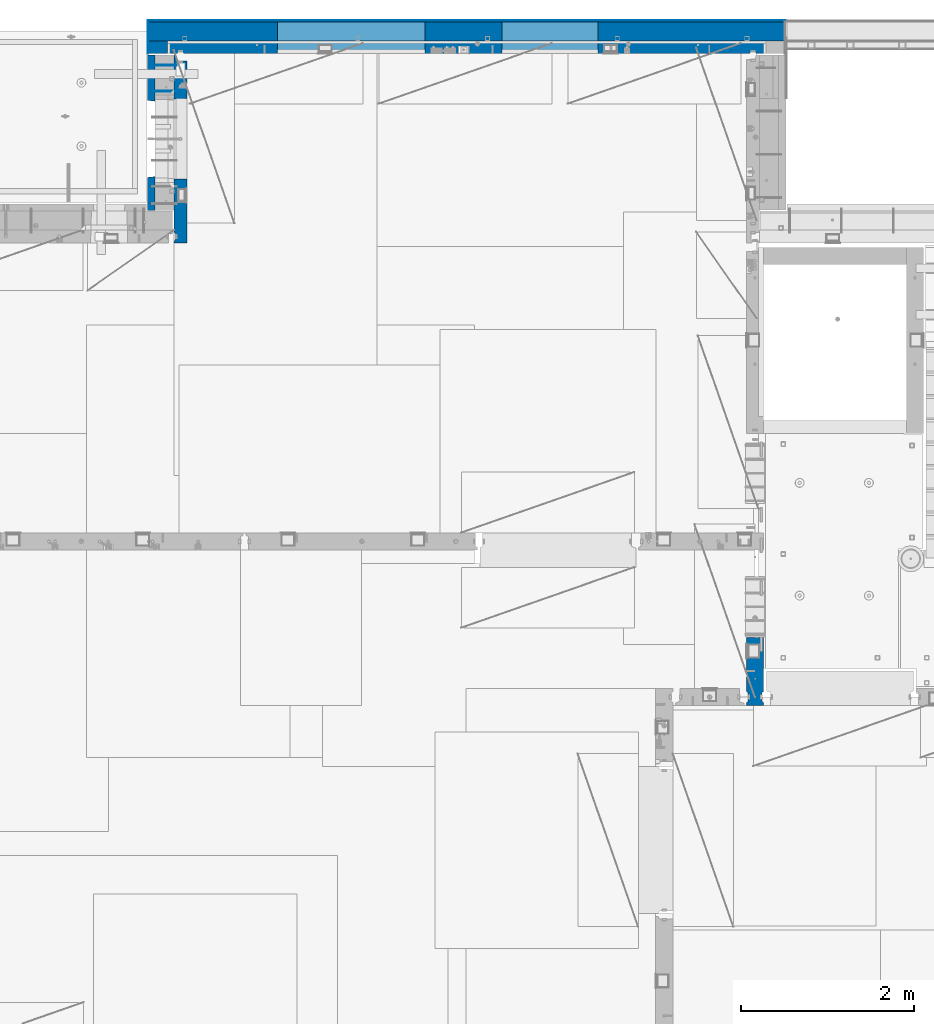
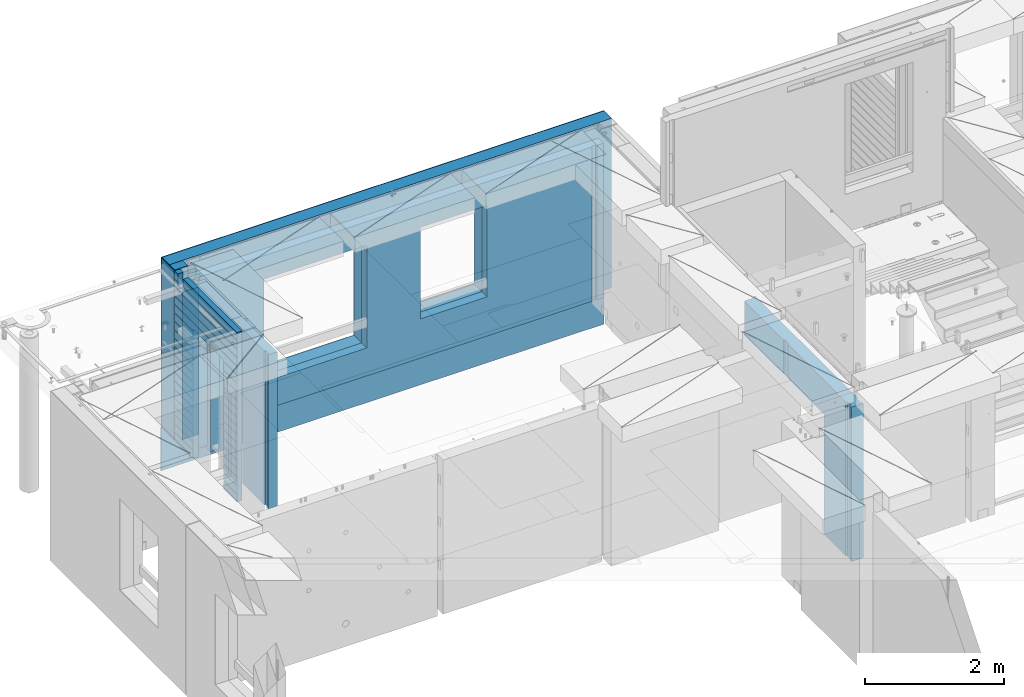
# One storey, part 237 of 350: 11 walls, 4 elements without a shape of their own.
"""IFC2X3 building model written with IfcOpenShell, lengths in millimetres."""

from ifc_helpers import new_model, si_unit, frame, origin_with_axes, place, context, subcontext, project, spatial, faceted_brep, material, type_object, element, aggregate, save


model = new_model("IFC2X3")

# Units and contexts
model_context = context("Model", 3, precision=1e-05, world=origin_with_axes())
body_context = subcontext(model_context, "Body", "Model", "MODEL_VIEW")
ifc_project = project(units=[si_unit("LENGTHUNIT", "METRE", prefix="MILLI"), si_unit("AREAUNIT", "SQUARE_METRE"), si_unit("VOLUMEUNIT", "CUBIC_METRE"), si_unit("MASSUNIT", "GRAM", prefix="KILO"), si_unit("TIMEUNIT", "SECOND"), si_unit("PLANEANGLEUNIT", "RADIAN"), si_unit("SOLIDANGLEUNIT", "STERADIAN"), si_unit("THERMODYNAMICTEMPERATUREUNIT", "DEGREE_CELSIUS"), si_unit("LUMINOUSINTENSITYUNIT", "LUMEN")], contexts=[model_context])

# Site, building, storey
site_placement = place(None, origin_with_axes())
site = spatial("IfcSite", under=ifc_project, at=site_placement, CompositionType="ELEMENT")
building_placement = place(site_placement, origin_with_axes())
building = spatial("IfcBuilding", under=site, at=building_placement, CompositionType="ELEMENT")
storey_placement = place(building_placement, origin_with_axes())
storey = spatial("IfcBuildingStorey", under=building, at=storey_placement, Name="2", CompositionType="ELEMENT", Elevation=0.0)

# Assembly, wall
assembly_1_placement = place(storey_placement, origin_with_axes())
assembly_1 = element("IfcElementAssembly", 1, at=assembly_1_placement, inside=storey, AssemblyPlace="NOTDEFINED", PredefinedType="REINFORCEMENT_UNIT")
ifc_material_1 = material(Name="CONCRETE/C30/37")
wall_type_1 = type_object("IfcWallType", PredefinedType="NOTDEFINED")
wall_1_placement = place(assembly_1_placement, frame((18064.9999998805, 23004.9999980536, 84357.5), z_axis=(0.0, 0.0, 1.0), x_axis=(-1.0, 3.00000001838171e-08, 0.0)))
wall_1 = element("IfcWall", 2, at=wall_1_placement, type_object=wall_type_1, material=ifc_material_1, context=body_context, shape_type="Brep", body=[
    faceted_brep([(0.0, 5.0, -382.5), (0.0, 5.0, 382.5), (7380.0035203153, 5.0, 382.5), (7380.0035203153, 5.0, -382.5), (-3.63797880709171e-12, -5.0, 382.5), (7380.0035203153, -5.0, 382.5), (-3.63797880709171e-12, -5.0, -382.5), (7380.0035203153, -5.0, -382.5)], [[[0, 1, 2, 3]], [[1, 4, 5, 2]], [[4, 6, 7, 5]], [[6, 0, 3, 7]], [[5, 7, 3, 2]], [[6, 4, 1, 0]]]),
])
aggregate(assembly_1, [wall_1])

# Assembly, walls
assembly_2_placement = place(storey_placement, origin_with_axes())
assembly_2 = element("IfcElementAssembly", 3, at=assembly_2_placement, inside=storey, AssemblyPlace="NOTDEFINED", PredefinedType="REINFORCEMENT_UNIT")
ifc_material_2 = material(Name="Undefined")
wall_type_2 = type_object("IfcWallType", PredefinedType="NOTDEFINED")
wall_2_placement = place(assembly_2_placement, frame((11020.0, 22485.0002441406, 86115.0), z_axis=(0.0, 0.0, 1.0), x_axis=(-1.0, 3.00000001838171e-08, 0.0)))
wall_2 = element("IfcWall", 4, at=wall_2_placement, type_object=wall_type_2, material=ifc_material_2, Name="(PD)", context=body_context, shape_type="Brep", body=[
    faceted_brep([(0.0, 5.0, -1300.0), (0.0, 5.0, 1300.0), (280.0, 5.0, 1300.0), (280.0, 5.0, -1300.0), (0.0, -5.0, 1300.0), (280.0, -5.0, 1300.0), (0.0, -5.0, -1300.0), (280.0, -5.0, -1300.0)], [[[0, 1, 2, 3]], [[1, 4, 5, 2]], [[4, 6, 7, 5]], [[6, 0, 3, 7]], [[5, 7, 3, 2]], [[6, 4, 1, 0]]]),
])
wall_3_placement = place(assembly_2_placement, frame((11020.0, 22185.0002441406, 86115.0), z_axis=(0.0, 0.0, 1.0), x_axis=(-1.0, 3.00000001838171e-08, 0.0)))
wall_3 = element("IfcWall", 5, at=wall_3_placement, type_object=wall_type_2, material=ifc_material_2, Name="(PD)", context=body_context, shape_type="Brep", body=[
    faceted_brep([(0.0, 5.0, -1300.0), (0.0, 5.0, 1300.0), (280.0, 5.0, 1300.0), (280.0, 5.0, -1300.0), (0.0, -5.0, 1300.0), (280.0, -5.0, 1300.0), (0.0, -5.0, -1300.0), (280.0, -5.0, -1300.0)], [[[0, 1, 2, 3]], [[1, 4, 5, 2]], [[4, 6, 7, 5]], [[6, 0, 3, 7]], [[5, 7, 3, 2]], [[6, 4, 1, 0]]]),
])

# Assembly, wall
assembly_3_placement = place(storey_placement, origin_with_axes())
assembly_3 = element("IfcElementAssembly", 6, at=assembly_3_placement, inside=storey, AssemblyPlace="NOTDEFINED", PredefinedType="REINFORCEMENT_UNIT")
ifc_material_3 = material(Name="CONCRETE/C25/30")
wall_type_3 = type_object("IfcWallType", PredefinedType="NOTDEFINED")
wall_4_placement = place(assembly_3_placement, frame((17710.0, 15080.0, 86112.5), z_axis=(0.0, 0.0, 1.0), x_axis=(0.0, 1.0, 0.0)))
wall_4 = element("IfcWall", 7, at=wall_4_placement, type_object=wall_type_3, material=ifc_material_3, context=body_context, shape_type="Brep", body=[
    faceted_brep([(3089.99926636568, -57.0, 1357.5), (3089.99926636568, -57.0, 762.5), (3089.99926620436, 100.0, 762.5), (3089.99926636568, 100.0, 1357.5), (3119.99926636568, -70.0, 1357.5), (3119.99926636568, -69.9999995451544, 762.5), (1965.00000368528, 100.0, 1357.5), (1965.00000368528, 99.9999997455598, 762.5), (1951.9999991369, 80.0000000823711, 762.5), (1951.9999991369, 80.0000000823711, 1357.5), (1848.00000041054, 79.9999993903439, 762.5), (1848.00000041054, 79.9999993903439, 1357.5), (1835.0, 100.0, 762.5), (1835.0, 100.0, 1357.5), (790.003238525391, -100.0, -1357.5), (790.003238525391, 100.0, -1357.5), (790.003238525391, 100.0, 762.5), (790.003238525391, -100.0, 762.5), (164.999999999998, 100.0, -1357.5), (164.999999999996, 100.0, 1357.5), (47.9997742438973, -79.9991481948964, 1357.5), (47.9997742438991, -79.9991481948928, -1357.5), (152.000000457021, -79.9991466091124, -1357.5), (152.000000457019, -79.9991466091124, 1357.5), (34.9997701872417, -100.0, 1357.5), (34.9997701872435, -100.0, -1357.5), (0.0, -100.0, 1357.5), (0.0, -100.0, -1357.5), (0.0, 100.0, 1357.5), (0.0, 100.0, -1357.5), (35.0, 100.0, 1357.5), (35.0, 100.0, -1357.5), (48.0, 80.0, 1357.5), (48.0, 80.0, -1357.5), (152.0, 80.0, 1357.5), (152.0, 80.0, -1357.5), (165.0, -100.0, -1357.5), (164.999999999998, -99.9991455078125, 1357.5), (3119.99926636568, -100.0, 762.5), (3119.99926636568, -100.0, 1357.5)], [[[0, 1, 2, 3]], [[4, 5, 1, 0]], [[6, 7, 8, 9]], [[9, 8, 10, 11]], [[11, 10, 12, 13]], [[14, 15, 16, 17]], [[13, 12, 16, 15, 18, 19]], [[20, 21, 22, 23]], [[24, 25, 21, 20]], [[26, 27, 25, 24]], [[27, 26, 28, 29]], [[29, 28, 30, 31]], [[32, 33, 31, 30]], [[34, 35, 33, 32]], [[19, 18, 35, 34]], [[15, 14, 36, 22, 21, 25, 27, 29, 31, 33, 35, 18]], [[37, 23, 22, 36]], [[14, 17, 38, 39, 37, 36]], [[13, 19, 34, 32, 30, 28, 26, 24, 20, 23, 37, 39, 4, 0, 3, 6, 9, 11]], [[7, 6, 3, 2]], [[38, 17, 16, 12, 10, 8, 7, 2, 1, 5]], [[39, 38, 5, 4]]]),
])
aggregate(assembly_3, [wall_4])

# Assembly, walls
assembly_4_placement = place(storey_placement, origin_with_axes())
assembly_4 = element("IfcElementAssembly", 8, at=assembly_4_placement, inside=storey, AssemblyPlace="NOTDEFINED", PredefinedType="REINFORCEMENT_UNIT")
ifc_material_4 = material()
wall_type_4 = type_object("IfcWallType", PredefinedType="NOTDEFINED")
wall_5_placement = place(assembly_4_placement, frame((10805.0, 22620.0, 86247.5), z_axis=(0.0, 0.0, 1.0), x_axis=(0.0, 1.0, 0.0)))
wall_5 = element("IfcWall", 9, at=wall_5_placement, type_object=wall_type_4, material=ifc_material_4, context=body_context, shape_type="Brep", body=[
    faceted_brep([(0.0, 110.0, -1492.5), (0.0, 110.0, 1492.5), (150.0, 110.0, 1492.5), (150.0, 110.0, -1492.5), (0.0, -110.0, 1492.5), (150.0, -110.0, 1492.5), (0.0, -110.0, -1492.5), (150.0, -110.0, -1492.5)], [[[0, 1, 2, 3]], [[1, 4, 5, 2]], [[4, 6, 7, 5]], [[6, 0, 3, 7]], [[5, 7, 3, 2]], [[6, 4, 1, 0]]]),
])
wall_6_placement = place(assembly_4_placement, frame((10915.0, 22880.0, 86247.5), z_axis=(0.0, 0.0, 1.0), x_axis=(1.0, 0.0, 0.0)))
wall_6 = element("IfcWall", 10, at=wall_6_placement, type_object=wall_type_4, material=ifc_material_4, context=body_context, shape_type="Brep", body=[
    faceted_brep([(3869.99997871358, 110.0, 807.5), (3869.99997871358, -110.0, 807.5), (3869.99997871358, -110.0, -802.5), (3869.99997871358, 110.0, -802.5), (4979.99997871358, -110.0, -802.5), (4979.99997871358, 110.0, -802.5), (4979.99997871358, -110.0, 807.5), (4979.99997871358, 110.0, 807.5), (-220.0, 110.0, 1492.5), (-220.0, -110.0, 1492.5), (7140.0, -110.0, 1492.5), (7140.0, 110.0, 1492.5), (-220.0, -110.0, -1492.5), (-220.0, 110.0, -1492.5), (7140.0, 110.0, -1492.5), (7140.0, -110.0, -1492.5), (1270.00055091817, 110.0, -1002.5), (2980.00055091817, 110.0, -1002.5), (2980.00055091817, 110.0, 807.5), (1270.00055091817, 110.0, 807.5), (1270.00055091817, -110.0, -1002.5), (2980.00055091817, -110.0, -1002.5), (1270.00055091817, -110.0, 807.5), (2980.00055091817, -110.0, 807.5)], [[[0, 1, 2, 3]], [[3, 2, 4, 5]], [[5, 4, 6, 7]], [[7, 6, 1, 0]], [[8, 9, 10, 11]], [[12, 9, 8, 13]], [[12, 13, 14, 15]], [[10, 15, 14, 11]], [[13, 8, 11, 14], [3, 5, 7, 0], [16, 17, 18, 19]], [[16, 20, 21, 17]], [[19, 22, 20, 16]], [[18, 23, 22, 19]], [[17, 21, 23, 18]], [[9, 12, 15, 10], [2, 1, 6, 4], [20, 22, 23, 21]]]),
])

# Wall
wall_type_5 = type_object("IfcWallType", PredefinedType="NOTDEFINED")
wall_7_placement = place(assembly_2_placement, frame((10727.5, 20805.0, 86247.5), z_axis=(0.0, 0.0, 1.0), x_axis=(0.0, 1.0, 0.0)))
wall_7 = element("IfcWall", 11, at=wall_7_placement, type_object=wall_type_5, material=ifc_material_1, context=body_context, shape_type="Brep", body=[
    faceted_brep([(1800.0, -42.5, 1492.5), (1800.0, 42.5, 1492.5), (1705.0, 42.5, 1492.5), (1705.0, -42.5, 1492.5), (0.0, 42.5, -1492.5), (0.0, 42.5, -1357.00000005524), (384.998212827581, 42.5, -1357.00000005524), (384.998212827581, 42.5, -1492.5), (0.0, 32.4999992507037, -1355.00000000074), (386.174879582417, 32.4999992506928, -1355.0000000008), (0.0, 32.4999991127006, -1344.99999959956), (386.174879598653, 32.4999991126915, -1344.99999959957), (0.0, 42.5, -1343.00000011075), (384.998212827581, 42.5, -1343.00000011075), (0.0, 42.5, -1207.00000005524), (384.998212827581, 42.5, -1207.00000005524), (0.0, 32.4999992507037, -1205.00000000074), (386.174879582417, 32.4999992506928, -1205.0000000008), (0.0, 32.4999991127006, -1194.99999959956), (386.174879598653, 32.4999991126915, -1194.99999959957), (0.0, 42.5, -1193.00000011075), (384.998212827581, 42.5, -1193.00000011075), (0.0, 42.5, -1057.00000005524), (384.998212827581, 42.5, -1057.00000005524), (0.0, 32.4999992507037, -1055.00000000074), (386.174879582417, 32.4999992506928, -1055.0000000008), (0.0, 32.4999991127006, -1044.99999959956), (386.174879598653, 32.4999991126915, -1044.99999959957), (0.0, 42.5, -1043.00000011075), (384.998212827581, 42.5, -1043.00000011075), (0.0, 42.5, -907.000000055239), (384.998212827581, 42.5, -907.000000055239), (0.0, 32.4999992507037, -905.000000000742), (386.174879582417, 32.4999992506928, -905.0000000008), (0.0, 32.4999991127006, -894.99999959956), (386.174879598653, 32.4999991126915, -894.999999599575), (0.0, 42.5, -893.000000110755), (384.998212827581, 42.5, -893.000000110755), (0.0, 42.5, -757.000000055239), (384.998212827581, 42.5, -757.000000055239), (0.0, 32.4999992507037, -755.000000000742), (386.174879582417, 32.4999992506928, -755.0000000008), (0.0, 32.4999991127006, -744.99999959956), (386.174879598653, 32.4999991126915, -744.999999599575), (0.0, 42.5, -743.000000110755), (384.998212827581, 42.5, -743.000000110755), (0.0, 42.5, -607.000000055239), (384.998212827581, 42.5, -607.000000055239), (3.63797880709171e-12, 32.4999992507037, -605.000000000742), (386.174879582417, 32.4999992506928, -605.0000000008), (3.63797880709171e-12, 32.4999991127006, -594.99999959956), (386.174879598653, 32.4999991126915, -594.999999599575), (0.0, 42.5, -593.000000110755), (384.998212827581, 42.5, -593.000000110755), (0.0, 42.5, -457.000000055239), (384.998212827581, 42.5, -457.000000055239), (0.0, 32.4999992507037, -455.000000000742), (386.174879582417, 32.4999992506928, -455.0000000008), (0.0, 32.4999991127006, -444.99999959956), (386.174879598653, 32.4999991126915, -444.999999599575), (0.0, 42.5, -443.000000110755), (384.998212827581, 42.5, -443.000000110755), (0.0, 42.5, -307.000000055239), (384.998212827581, 42.5, -307.000000055239), (0.0, 32.4999992507037, -305.000000000742), (386.174879582417, 32.4999992506928, -305.0000000008), (0.0, 32.4999991127006, -294.99999959956), (386.174879598653, 32.4999991126915, -294.999999599575), (0.0, 42.5, -293.000000110755), (384.998212827581, 42.5, -293.000000110755), (0.0, 42.5, -157.000000055239), (384.998212827581, 42.5, -157.000000055239), (3.63797880709171e-12, 32.4999992507037, -155.000000000742), (386.174879582417, 32.4999992506928, -155.0000000008), (3.63797880709171e-12, 32.4999991127006, -144.99999959956), (386.174879598653, 32.4999991126915, -144.999999599575), (0.0, 42.5, -143.000000110755), (384.998212827581, 42.5, -143.000000110755), (0.0, 42.5, -7.00000005523907), (384.998212827581, 42.5, -7.00000005523907), (0.0, 32.4999992507037, -5.00000000074215), (386.174879582417, 32.4999992506928, -5.00000000080036), (0.0, 32.4999991127006, 5.0000004004396), (386.174879598653, 32.4999991126915, 5.00000040042505), (0.0, 42.5, 6.99999988924537), (384.998212827581, 42.5, 6.99999988924537), (0.0, 42.5, 142.999999944761), (384.998212827581, 42.5, 142.999999944761), (-3.63797880709171e-12, 32.4999992507037, 144.999999999258), (386.174879582417, 32.4999992506928, 144.9999999992), (-3.63797880709171e-12, 32.4999991127006, 155.00000040044), (386.174879598653, 32.4999991126915, 155.000000400425), (0.0, 42.5, 156.999999889245), (384.998212827581, 42.5, 156.999999889245), (0.0, 42.5, 292.999999944761), (384.998212827581, 42.5, 292.999999944761), (-3.63797880709171e-12, 32.4999992507037, 294.999999999258), (386.174879582417, 32.4999992506928, 294.9999999992), (-3.63797880709171e-12, 32.4999991127006, 305.00000040044), (386.174879598653, 32.4999991126915, 305.000000400425), (0.0, 42.5, 306.999999889245), (384.998212827581, 42.5, 306.999999889245), (0.0, 42.5, 442.999999944761), (384.998212827581, 42.5, 442.999999944761), (0.0, 32.4999992507037, 444.999999999258), (386.174879582417, 32.4999992506928, 444.9999999992), (0.0, 32.4999991127006, 455.00000040044), (386.174879598653, 32.4999991126915, 455.000000400425), (0.0, 42.5, 456.999999889245), (384.998212827581, 42.5, 456.999999889245), (0.0, 42.5, 592.999999944761), (384.998212827581, 42.5, 592.999999944761), (3.63797880709171e-12, 32.4999992507037, 594.999999999258), (386.174879582417, 32.4999992506928, 594.9999999992), (3.63797880709171e-12, 32.4999991127006, 605.00000040044), (386.174879598653, 32.4999991126915, 605.000000400425), (0.0, 42.5, 606.999999889245), (384.998212827581, 42.5, 606.999999889245), (0.0, 42.5, 742.999999944761), (384.998212827581, 42.5, 742.999999944761), (0.0, 32.4999992507037, 744.999999999258), (386.174879582417, 32.4999992506928, 744.9999999992), (0.0, 32.4999991127006, 755.00000040044), (386.174879598653, 32.4999991126915, 755.000000400425), (0.0, 42.5, 756.999999889245), (384.998212827581, 42.5, 756.999999889245), (0.0, 42.5, 1206.99999988925), (1800.0, 42.5, 1206.99999988925), (1800.0, 32.4999991126897, 1205.00000040043), (0.0, 32.4999991127006, 1205.00000040044), (1800.0, 32.4999992507001, 1194.99999999923), (0.0, 32.4999992507037, 1194.99999999926), (0.0, 42.5, 1192.99999994476), (1800.0, 42.5, 1192.99999994476), (1800.0, 42.5, 1056.99999988925), (0.0, 42.5, 1056.99999988925), (1800.0, 32.4999991126897, 1055.00000040043), (0.0, 32.4999991127006, 1055.00000040044), (1800.0, 32.4999992507001, 1044.99999999923), (0.0, 32.4999992507037, 1044.99999999926), (0.0, 42.5, 1042.99999994476), (1800.0, 42.5, 1042.99999994476), (1800.0, 42.5, 906.999999889245), (0.0, 42.5, 906.999999889245), (1800.0, 32.4999991126897, 905.000000400425), (0.0, 32.4999991127006, 905.00000040044), (1800.0, 32.4999992507001, 894.999999999229), (0.0, 32.4999992507037, 894.999999999258), (0.0, 42.5, 892.999999944761), (1800.0, 42.5, 892.999999944761), (1800.0, 42.5, -1357.00000005524), (1800.0, 42.5, -1492.5), (1274.99821282758, 42.5, -1492.5), (1274.99821282758, 42.5, -1357.00000005524), (1800.0, 32.4999992507001, -1355.00000000077), (1273.82154607274, 32.4999992506928, -1355.0000000008), (1800.0, 32.4999991126897, -1344.99999959957), (1273.82154605651, 32.4999991126915, -1344.99999959957), (1800.0, 42.5, -1343.00000011075), (1274.99821282758, 42.5, -1343.00000011075), (1800.0, 42.5, -1207.00000005524), (1274.99821282758, 42.5, -1207.00000005524), (1800.0, 32.4999992507001, -1205.00000000077), (1273.82154607274, 32.4999992506928, -1205.0000000008), (1800.0, 32.4999991126897, -1194.99999959957), (1273.82154605651, 32.4999991126915, -1194.99999959957), (1800.0, 42.5, -1193.00000011075), (1274.99821282758, 42.5, -1193.00000011075), (1800.0, 42.5, -1057.00000005524), (1274.99821282758, 42.5, -1057.00000005524), (1800.0, 32.4999992507001, -1055.00000000077), (1273.82154607274, 32.4999992506928, -1055.0000000008), (1800.0, 32.4999991126897, -1044.99999959957), (1273.82154605651, 32.4999991126915, -1044.99999959957), (1800.0, 42.5, -1043.00000011075), (1274.99821282758, 42.5, -1043.00000011075), (1800.0, 42.5, -907.000000055239), (1274.99821282758, 42.5, -907.000000055239), (1800.0, 32.4999992507001, -905.000000000771), (1273.82154607274, 32.4999992506928, -905.0000000008), (1800.0, 32.4999991126897, -894.999999599575), (1273.82154605651, 32.4999991126915, -894.999999599575), (1800.0, 42.5, -893.000000110755), (1274.99821282758, 42.5, -893.000000110755), (1800.0, 42.5, -757.000000055239), (1274.99821282758, 42.5, -757.000000055239), (1800.0, 32.4999992507001, -755.000000000771), (1273.82154607274, 32.4999992506928, -755.0000000008), (1800.0, 32.4999991126897, -744.999999599575), (1273.82154605651, 32.4999991126915, -744.999999599575), (1800.0, 42.5, -743.000000110755), (1274.99821282758, 42.5, -743.000000110755), (1800.0, 42.5, -607.000000055239), (1274.99821282758, 42.5, -607.000000055239), (1800.0, 32.4999992507001, -605.000000000771), (1273.82154607274, 32.4999992506928, -605.0000000008), (1800.0, 32.4999991126897, -594.999999599575), (1273.82154605651, 32.4999991126915, -594.999999599575), (1800.0, 42.5, -593.000000110755), (1274.99821282758, 42.5, -593.000000110755), (1800.0, 42.5, -457.000000055239), (1274.99821282758, 42.5, -457.000000055239), (1800.0, 32.4999992507001, -455.000000000771), (1273.82154607274, 32.4999992506928, -455.0000000008), (1800.0, 32.4999991126897, -444.999999599575), (1273.82154605651, 32.4999991126915, -444.999999599575), (1800.0, 42.5, -443.000000110755), (1274.99821282758, 42.5, -443.000000110755), (1800.0, 42.5, -307.000000055239), (1274.99821282758, 42.5, -307.000000055239), (1800.0, 32.4999992507001, -305.000000000771), (1273.82154607274, 32.4999992506928, -305.0000000008), (1800.0, 32.4999991126897, -294.999999599575), (1273.82154605651, 32.4999991126915, -294.999999599575), (1800.0, 42.5, -293.000000110755), (1274.99821282758, 42.5, -293.000000110755), (1800.0, 42.5, -157.000000055239), (1274.99821282758, 42.5, -157.000000055239), (1800.0, 32.4999992507001, -155.000000000771), (1273.82154607274, 32.4999992506928, -155.0000000008), (1800.0, 32.4999991126897, -144.999999599575), (1273.82154605651, 32.4999991126915, -144.999999599575), (1800.0, 42.5, -143.000000110755), (1274.99821282758, 42.5, -143.000000110755), (1800.0, 42.5, -7.00000005523907), (1274.99821282758, 42.5, -7.00000005523907), (1800.0, 32.4999992507001, -5.00000000077125), (1273.82154607274, 32.4999992506928, -5.00000000080036), (1800.0, 32.4999991126897, 5.00000040042505), (1273.82154605651, 32.4999991126915, 5.00000040042505), (1800.0, 42.5, 6.99999988924537), (1274.99821282758, 42.5, 6.99999988924537), (1800.0, 42.5, 142.999999944761), (1274.99821282758, 42.5, 142.999999944761), (1800.0, 32.4999992507001, 144.999999999229), (1273.82154607274, 32.4999992506928, 144.9999999992), (1800.0, 32.4999991126897, 155.000000400425), (1273.82154605651, 32.4999991126915, 155.000000400425), (1800.0, 42.5, 156.999999889245), (1274.99821282758, 42.5, 156.999999889245), (1800.0, 42.5, 292.999999944761), (1274.99821282758, 42.5, 292.999999944761), (1800.0, 32.4999992507001, 294.999999999229), (1273.82154607274, 32.4999992506928, 294.9999999992), (1800.0, 32.4999991126897, 305.000000400425), (1273.82154605651, 32.4999991126915, 305.000000400425), (1800.0, 42.5, 306.999999889245), (1274.99821282758, 42.5, 306.999999889245), (1800.0, 42.5, 442.999999944761), (1274.99821282758, 42.5, 442.999999944761), (1800.0, 32.4999992507001, 444.999999999229), (1273.82154607274, 32.4999992506928, 444.9999999992), (1800.0, 32.4999991126897, 455.000000400425), (1273.82154605651, 32.4999991126915, 455.000000400425), (1800.0, 42.5, 456.999999889245), (1274.99821282758, 42.5, 456.999999889245), (1800.0, 42.5, 592.999999944761), (1274.99821282758, 42.5, 592.999999944761), (1800.0, 32.4999992507001, 594.999999999229), (1273.82154607274, 32.4999992506928, 594.9999999992), (1800.0, 32.4999991126897, 605.000000400425), (1273.82154605651, 32.4999991126915, 605.000000400425), (1800.0, 42.5, 606.999999889245), (1274.99821282758, 42.5, 606.999999889245), (1800.0, 42.5, 742.999999944761), (1274.99821282758, 42.5, 742.999999944761), (1800.0, 32.4999992507001, 744.999999999229), (1273.82154607274, 32.4999992506928, 744.9999999992), (1800.0, 32.4999991126897, 755.000000400425), (1273.82154605651, 32.4999991126915, 755.000000400425), (1800.0, 42.5, 756.999999889245), (1274.99821282758, 42.5, 756.999999889245), (395.000271651108, 42.5, 782.5), (384.998212827581, 42.5, 782.5), (1274.99821282758, 42.5, 782.5), (1265.00027165111, 42.5, 782.5), (394.999879494248, -42.5, 787.502857142856), (1264.99654616091, -42.5, 787.502857142856), (394.999879494248, -42.5, 782.5), (394.999879494248, -42.5, -1492.5), (0.0, -42.5, -1492.5), (-3.63797880709171e-12, 32.4999992507037, 1344.99999999926), (0.0, 42.5, 1342.99999994476), (0.0, -42.5, 1492.5), (0.0, 42.5, 1492.5), (0.0, 42.5, 1356.99999988925), (-3.63797880709171e-12, 32.4999991127006, 1355.00000040044), (1555.0, 42.5, 1356.99999988925), (1555.0, 32.4999991126915, 1355.00000040043), (1555.0, 32.4999992506928, 1344.9999999992), (1555.0, 42.5, 1342.99999994476), (1800.0, 42.5, 1342.99999994476), (1555.0, 42.5, 1222.5), (1705.0, 42.5, 1222.5), (1705.0, 42.5, 1343.0), (1800.0, 32.4999992507001, 1344.99999999923), (1705.0, 32.5, 1345.0), (1800.0, 32.4999991126897, 1355.00000040043), (1705.0, 32.5, 1355.0), (1800.0, 42.5, 1356.99999988925), (1705.0, 42.5, 1357.0), (1800.0, -42.5, -1492.5), (1264.99654616091, -42.5, -1492.5), (1264.99654616091, -42.5, 782.5), (1705.0, -42.5, 1222.5), (1555.0, -42.5, 1222.5), (1555.0, -42.5, 1492.5), (1555.0, 42.5, 1492.5)], [[[0, 1, 2, 3]], [[4, 5, 6, 7]], [[5, 8, 9, 6]], [[8, 10, 11, 9]], [[10, 12, 13, 11]], [[12, 14, 15, 13]], [[14, 16, 17, 15]], [[16, 18, 19, 17]], [[18, 20, 21, 19]], [[20, 22, 23, 21]], [[22, 24, 25, 23]], [[24, 26, 27, 25]], [[26, 28, 29, 27]], [[28, 30, 31, 29]], [[30, 32, 33, 31]], [[32, 34, 35, 33]], [[34, 36, 37, 35]], [[36, 38, 39, 37]], [[38, 40, 41, 39]], [[40, 42, 43, 41]], [[42, 44, 45, 43]], [[44, 46, 47, 45]], [[46, 48, 49, 47]], [[48, 50, 51, 49]], [[50, 52, 53, 51]], [[52, 54, 55, 53]], [[54, 56, 57, 55]], [[56, 58, 59, 57]], [[58, 60, 61, 59]], [[60, 62, 63, 61]], [[62, 64, 65, 63]], [[64, 66, 67, 65]], [[66, 68, 69, 67]], [[68, 70, 71, 69]], [[70, 72, 73, 71]], [[72, 74, 75, 73]], [[74, 76, 77, 75]], [[76, 78, 79, 77]], [[78, 80, 81, 79]], [[80, 82, 83, 81]], [[82, 84, 85, 83]], [[84, 86, 87, 85]], [[86, 88, 89, 87]], [[88, 90, 91, 89]], [[90, 92, 93, 91]], [[92, 94, 95, 93]], [[94, 96, 97, 95]], [[96, 98, 99, 97]], [[98, 100, 101, 99]], [[100, 102, 103, 101]], [[102, 104, 105, 103]], [[104, 106, 107, 105]], [[106, 108, 109, 107]], [[108, 110, 111, 109]], [[110, 112, 113, 111]], [[112, 114, 115, 113]], [[114, 116, 117, 115]], [[116, 118, 119, 117]], [[118, 120, 121, 119]], [[120, 122, 123, 121]], [[122, 124, 125, 123]], [[126, 127, 128, 129]], [[129, 128, 130, 131]], [[132, 131, 130, 133]], [[134, 135, 132, 133]], [[135, 134, 136, 137]], [[137, 136, 138, 139]], [[140, 139, 138, 141]], [[142, 143, 140, 141]], [[143, 142, 144, 145]], [[145, 144, 146, 147]], [[148, 147, 146, 149]], [[150, 151, 152, 153]], [[154, 150, 153, 155]], [[156, 154, 155, 157]], [[158, 156, 157, 159]], [[160, 158, 159, 161]], [[162, 160, 161, 163]], [[164, 162, 163, 165]], [[166, 164, 165, 167]], [[168, 166, 167, 169]], [[170, 168, 169, 171]], [[172, 170, 171, 173]], [[174, 172, 173, 175]], [[176, 174, 175, 177]], [[178, 176, 177, 179]], [[180, 178, 179, 181]], [[182, 180, 181, 183]], [[184, 182, 183, 185]], [[186, 184, 185, 187]], [[188, 186, 187, 189]], [[190, 188, 189, 191]], [[192, 190, 191, 193]], [[194, 192, 193, 195]], [[196, 194, 195, 197]], [[198, 196, 197, 199]], [[200, 198, 199, 201]], [[202, 200, 201, 203]], [[204, 202, 203, 205]], [[206, 204, 205, 207]], [[208, 206, 207, 209]], [[210, 208, 209, 211]], [[212, 210, 211, 213]], [[214, 212, 213, 215]], [[216, 214, 215, 217]], [[218, 216, 217, 219]], [[220, 218, 219, 221]], [[222, 220, 221, 223]], [[224, 222, 223, 225]], [[226, 224, 225, 227]], [[228, 226, 227, 229]], [[230, 228, 229, 231]], [[232, 230, 231, 233]], [[234, 232, 233, 235]], [[236, 234, 235, 237]], [[238, 236, 237, 239]], [[240, 238, 239, 241]], [[242, 240, 241, 243]], [[244, 242, 243, 245]], [[246, 244, 245, 247]], [[248, 246, 247, 249]], [[250, 248, 249, 251]], [[252, 250, 251, 253]], [[254, 252, 253, 255]], [[256, 254, 255, 257]], [[258, 256, 257, 259]], [[260, 258, 259, 261]], [[262, 260, 261, 263]], [[264, 262, 263, 265]], [[266, 264, 265, 267]], [[268, 266, 267, 269]], [[270, 268, 269, 271]], [[272, 273, 125, 124, 148, 149, 270, 271, 274, 275]], [[276, 273, 272, 275, 274, 277]], [[278, 279, 7, 6, 9, 11, 13, 15, 17, 19, 21, 23, 25, 27, 29, 31, 33, 35, 37, 39, 41, 43, 45, 47, 49, 51, 53, 55, 57, 59, 61, 63, 65, 67, 69, 71, 73, 75, 77, 79, 81, 83, 85, 87, 89, 91, 93, 95, 97, 99, 101, 103, 105, 107, 109, 111, 113, 115, 117, 119, 121, 123, 125, 273, 276]], [[280, 4, 7, 279]], [[281, 282, 126, 129, 131, 132, 135, 137, 139, 140, 143, 145, 147, 148, 124, 122, 120, 118, 116, 114, 112, 110, 108, 106, 104, 102, 100, 98, 96, 94, 92, 90, 88, 86, 84, 82, 80, 78, 76, 74, 72, 70, 68, 66, 64, 62, 60, 58, 56, 54, 52, 50, 48, 46, 44, 42, 40, 38, 36, 34, 32, 30, 28, 26, 24, 22, 20, 18, 16, 14, 12, 10, 8, 5, 4, 280, 283, 284, 285, 286]], [[286, 285, 287, 288]], [[281, 286, 288, 289]], [[282, 281, 289, 290]], [[291, 127, 126, 282, 290, 292, 293, 294]], [[295, 291, 294, 296]], [[297, 295, 296, 298]], [[299, 297, 298, 300]], [[1, 0, 301, 151, 150, 154, 156, 158, 160, 162, 164, 166, 168, 170, 172, 174, 176, 178, 180, 182, 184, 186, 188, 190, 192, 194, 196, 198, 200, 202, 204, 206, 208, 210, 212, 214, 216, 218, 220, 222, 224, 226, 228, 230, 232, 234, 236, 238, 240, 242, 244, 246, 248, 250, 252, 254, 256, 258, 260, 262, 264, 266, 268, 270, 149, 146, 144, 142, 141, 138, 136, 134, 133, 130, 128, 127, 291, 295, 297, 299]], [[151, 301, 302, 152]], [[303, 277, 274, 271, 269, 267, 265, 263, 261, 259, 257, 255, 253, 251, 249, 247, 245, 243, 241, 239, 237, 235, 233, 231, 229, 227, 225, 223, 221, 219, 217, 215, 213, 211, 209, 207, 205, 203, 201, 199, 197, 195, 193, 191, 189, 187, 185, 183, 181, 179, 177, 175, 173, 171, 169, 167, 165, 163, 161, 159, 157, 155, 153, 152, 302]], [[302, 301, 0, 3, 304, 305, 306, 283, 280, 279, 278, 276, 277, 303]], [[284, 283, 306, 307]], [[285, 284, 307, 287]], [[306, 305, 292, 290, 289, 288, 287, 307]], [[304, 293, 292, 305]], [[3, 2, 300, 298, 296, 294, 293, 304]], [[1, 299, 300, 2]]]),
])

wall_type_6 = type_object("IfcWallType", PredefinedType="NOTDEFINED")
wall_8_placement = place(assembly_2_placement, frame((11065.0, 20430.0, 86112.5), z_axis=(0.0, 0.0, 1.0), x_axis=(0.0, 1.0, 0.0)))
wall_8 = element("IfcWall", 12, at=wall_8_placement, type_object=wall_type_6, material=ifc_material_3, context=body_context, shape_type="Brep", body=[
    faceted_brep([(124.995187227563, 75.0, 1357.5), (124.995187227563, 75.0, -1357.5), (114.995187227563, 55.0, -1357.5), (114.995187227563, 55.0, 1357.5), (-0.00481277243670775, -75.0, -1357.5), (-0.00481277243670775, -75.0, 1357.5), (-0.00481277243670775, 75.0, 1357.5), (-0.00481277243670775, 75.0, -1357.5), (24.9951872275633, 75.0, 1357.5), (24.9951872275633, 75.0, -1357.5), (34.9951872275633, 55.0, 1357.5), (34.9951872275633, 55.0, -1357.5), (47.9951869124525, 54.9999994175378, 1357.5), (47.9951869124525, 54.9999994175378, -1357.5), (101.995186816988, 54.9999993903693, 1357.5), (101.995186816988, 54.9999993903693, -1357.5), (2105.0, -75.0, 1357.5), (2105.0, 32.0, 1357.5), (2175.0, 45.0, 1357.5), (2175.0, 75.0, 1357.5), (2105.0, -75.0, -1357.5), (2105.0, 32.0, -1357.5), (2175.0, 45.0, -1357.5), (2175.0, 75.0, -1357.5), (743.846425497264, 75.0, -1357.5), (1666.15411780495, 75.0, -1357.5), (1666.15411780496, 75.0, 948.653846153844), (743.846425497261, 75.0, 948.653846153844), (740.000271651108, -75.0, -1357.5), (740.000271651108, -75.0, 952.5), (1670.00027165111, -75.0, 952.5), (1670.00027165111, -75.0, -1357.5)], [[[0, 1, 2, 3]], [[4, 5, 6, 7]], [[7, 6, 8, 9]], [[10, 11, 9, 8]], [[12, 13, 11, 10]], [[14, 15, 13, 12]], [[3, 2, 15, 14]], [[12, 10, 8, 6, 5, 16, 17, 18, 19, 0, 3, 14]], [[16, 20, 21, 17]], [[17, 21, 22, 18]], [[23, 19, 18, 22]], [[24, 1, 0, 19, 23, 25, 26, 27]], [[4, 7, 9, 11, 13, 15, 2, 1, 24, 28]], [[20, 16, 5, 4, 28, 29, 30, 31]], [[23, 22, 21, 20, 31, 25]], [[30, 26, 25, 31]], [[29, 27, 26, 30]], [[28, 24, 27, 29]]]),
])

aggregate(assembly_2, [wall_2, wall_3, wall_7, wall_8])

wall_9_placement = place(assembly_4_placement, frame((11142.5, 22695.0, 86112.5), z_axis=(0.0, 0.0, 1.0), x_axis=(1.0, 0.0, 0.0)))
wall_9 = element("IfcWall", 13, at=wall_9_placement, type_object=wall_type_6, material=ifc_material_3, context=body_context, shape_type="Brep", body=[
    faceted_brep([(3642.49997871358, 75.0, 942.5), (3642.49997871358, -75.0000009232135, 942.5), (3642.49997871358, -75.0000002283705, -667.5), (3642.49997871358, 75.0, -667.5), (4752.49997871358, -75.0000000404216, -667.5), (4752.49997871358, 75.0, -667.5), (4752.49997871358, -75.0000007352646, 942.5), (4752.49997871358, 75.0, 942.5), (6692.5, -75.0, -1357.5), (6692.5, -75.0, 1357.5), (6582.50000278437, -75.0000022790045, 1357.5), (6582.50000278437, -75.0, -1357.5), (-227.5, -75.0, -1357.5), (-227.5, -75.0, 1357.5), (-227.5, 75.0, 1357.5), (-227.5, 75.0, -1357.5), (-117.5, -75.0, -1357.5), (-117.5, -75.0, 1357.5), (-104.499999589396, -54.9999993903875, -1357.5), (-104.499999589396, -54.9999993903875, 1357.5), (-50.4999996848892, -54.9999994175341, -1357.5), (-50.4999996848892, -54.9999994175341, 1357.5), (-37.4999972154728, -75.0000022791319, 1357.5), (-37.4999972154728, -75.0, -1357.5), (6692.5, 75.0, 1357.5), (6502.49999792087, -75.0000000643449, 1357.5), (6515.49999996855, -54.9999999109496, 1357.5), (6569.49999987308, -54.999998745101, 1357.5), (6502.49999792087, -75.0, -1357.5), (6515.49999996855, -54.9999999109496, -1357.5), (6569.49999987308, -54.999998745101, -1357.5), (6692.5, 75.0, -1357.5), (1042.50055091817, 75.0, -867.5), (2752.50055091817, 75.0, -867.5), (2752.50055091817, 75.0, 942.5), (1042.50055091817, 75.0, 942.5), (1042.50055091817, -75.0000005925758, -867.5), (2752.50055091817, -75.0000003030254, -867.5), (1042.50055091817, -75.0000013522877, 942.5), (2752.50055091817, -75.0000010627373, 942.5)], [[[0, 1, 2, 3]], [[3, 2, 4, 5]], [[5, 4, 6, 7]], [[7, 6, 1, 0]], [[8, 9, 10, 11]], [[12, 13, 14, 15]], [[13, 12, 16, 17]], [[17, 16, 18, 19]], [[19, 18, 20, 21]], [[22, 21, 20, 23]], [[9, 24, 14, 13, 17, 19, 21, 22, 25, 26, 27, 10]], [[25, 28, 29, 26]], [[26, 29, 30, 27]], [[10, 27, 30, 11]], [[29, 28, 23, 20, 18, 16, 12, 15, 31, 8, 11, 30]], [[9, 8, 31, 24]], [[15, 14, 24, 31], [3, 5, 7, 0], [32, 33, 34, 35]], [[32, 36, 37, 33]], [[35, 38, 36, 32]], [[34, 39, 38, 35]], [[33, 37, 39, 34]], [[22, 23, 28, 25], [2, 1, 6, 4], [36, 38, 39, 37]]]),
])

wall_type_7 = type_object("IfcWallType", PredefinedType="NOTDEFINED")
wall_10_placement = place(assembly_4_placement, frame((10690.0, 22620.0, 86247.5), z_axis=(0.0, 0.0, 1.0), x_axis=(0.0, 1.0, 0.0)))
wall_10 = element("IfcWall", 14, at=wall_10_placement, type_object=wall_type_7, material=ifc_material_1, context=body_context, shape_type="Brep", body=[
    faceted_brep([(0.0, 5.0, -1492.5), (0.0, 5.0, 1492.5), (370.0, 5.0, 1492.5), (370.0, 5.0, -1492.5), (0.0, -5.0, 1492.5), (370.0, -5.0, 1492.5), (0.0, -5.0, -1492.5), (370.0, -5.0, -1492.5)], [[[0, 1, 2, 3]], [[1, 4, 5, 2]], [[4, 6, 7, 5]], [[6, 0, 3, 7]], [[5, 7, 3, 2]], [[6, 4, 1, 0]]]),
])

wall_11_placement = place(assembly_4_placement, frame((10915.0, 22995.0, 86247.5), z_axis=(0.0, 0.0, 1.0), x_axis=(1.0, 0.0, 0.0)))
wall_11 = element("IfcWall", 15, at=wall_11_placement, type_object=wall_type_7, material=ifc_material_1, context=body_context, shape_type="Brep", body=[
    faceted_brep([(3869.99997871358, 5.0, 807.5), (3869.99997871358, -5.0, 807.5), (3869.99997871358, -5.0, -802.5), (3869.99997871358, 5.0, -802.5), (4979.99997871358, -5.0, -802.5), (4979.99997871358, 5.0, -802.5), (4979.99997871358, -5.0, 807.5), (4979.99997871358, 5.0, 807.5), (-230.0, 5.0, 1492.5), (-230.0, -5.0, 1492.5), (7150.0, -5.0, 1492.5), (7150.0, 5.0, 1492.5), (-230.0, -5.0, -1492.5), (-230.0, 5.0, -1492.5), (7150.0, 5.0, -1492.5), (7150.0, -5.0, -1492.5), (1270.00055091817, 5.0, -1002.5), (2980.00055091817, 5.0, -1002.5), (2980.00055091817, 5.0, 807.5), (1270.00055091817, 5.0, 807.5), (1270.00055091817, -5.0, -1002.5), (2980.00055091817, -5.0, -1002.5), (1270.00055091817, -5.0, 807.5), (2980.00055091817, -5.0, 807.5)], [[[0, 1, 2, 3]], [[3, 2, 4, 5]], [[5, 4, 6, 7]], [[7, 6, 1, 0]], [[8, 9, 10, 11]], [[12, 9, 8, 13]], [[12, 13, 14, 15]], [[10, 15, 14, 11]], [[13, 8, 11, 14], [3, 5, 7, 0], [16, 17, 18, 19]], [[16, 20, 21, 17]], [[19, 22, 20, 16]], [[18, 23, 22, 19]], [[17, 21, 23, 18]], [[9, 12, 15, 10], [2, 1, 6, 4], [20, 22, 23, 21]]]),
])

aggregate(assembly_4, [wall_10, wall_5, wall_6, wall_11, wall_9])

save(model, "model.ifc")
